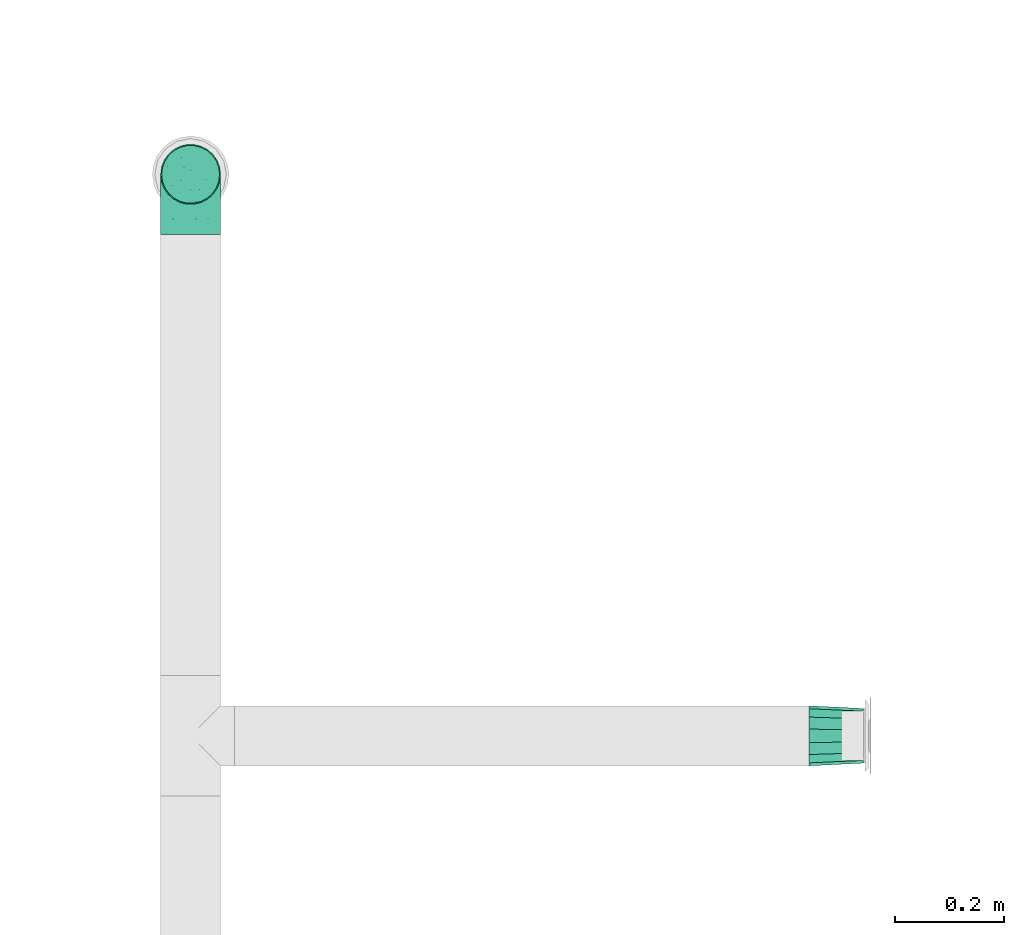
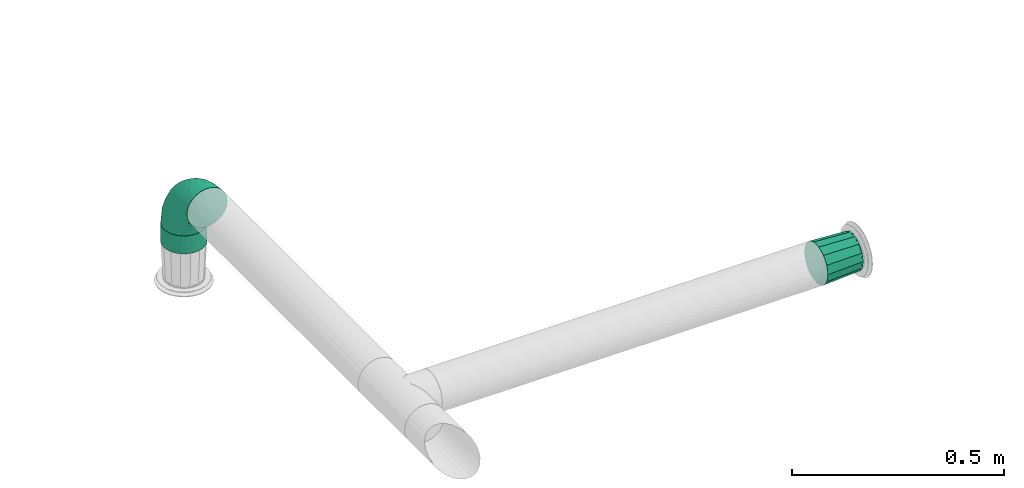
# One storey, part 63 of 115: 2 flow fittings, 1 flow segment.
"""IFC2X3 building model written with IfcOpenShell, lengths in millimetres."""

from ifc_helpers import new_model, entity, si_unit, converted_unit, derived_unit, direction, frame, origin_with_axes, origin_2d_with_axis, place, context, subcontext, project, spatial, hollow_circle, extrude, open_shell, surface_model, source, transform, mapped, material, layer, layer_set, layer_usage, type_object, element, save


model = new_model("IFC2X3")

# Units and contexts
model_context = context("Model", 3, precision=1e-05, world=origin_with_axes(), true_north=direction((0.0, 1.0)))
body_context = subcontext(model_context, "Body", "Model", "MODEL_VIEW")
ifc_project = project(units=[si_unit("AREAUNIT", "SQUARE_METRE"), si_unit("VOLUMEUNIT", "CUBIC_METRE", prefix="DECI"), si_unit("TIMEUNIT", "SECOND"), si_unit("THERMODYNAMICTEMPERATUREUNIT", "DEGREE_CELSIUS"), si_unit("PRESSUREUNIT", "PASCAL"), si_unit("MASSUNIT", "GRAM", prefix="KILO"), si_unit("LENGTHUNIT", "METRE", prefix="MILLI"), si_unit("POWERUNIT", "WATT"), si_unit("ELECTRICCURRENTUNIT", "AMPERE"), si_unit("ELECTRICVOLTAGEUNIT", "VOLT"), derived_unit("VOLUMETRICFLOWRATEUNIT", [(si_unit("VOLUMEUNIT", "CUBIC_METRE", prefix="DECI"), 1), (si_unit("TIMEUNIT", "SECOND"), -1)]), derived_unit("LINEARVELOCITYUNIT", [(si_unit("LENGTHUNIT", "METRE"), 1), (si_unit("TIMEUNIT", "SECOND"), -1)]), derived_unit("MASSDENSITYUNIT", [(si_unit("MASSUNIT", "GRAM", prefix="KILO"), 1), (si_unit("VOLUMEUNIT", "CUBIC_METRE"), -1)]), converted_unit("PLANEANGLEUNIT", "DEGREE", entity("IfcRatioMeasure", 0.01745), si_unit("PLANEANGLEUNIT", "RADIAN"), dimensions=[0, 0, 0, 0, 0, 0, 0])], contexts=[model_context])

# Site, building, storey
site_placement = place(None, origin_with_axes())
site = spatial("IfcSite", under=ifc_project, at=site_placement, CompositionType="ELEMENT")
building_placement = place(site_placement, origin_with_axes())
building = spatial("IfcBuilding", under=site, at=building_placement, Name="mc-building", CompositionType="ELEMENT")
storey_placement = place(building_placement, frame((0.0, 0.0, 2950.0), z_axis=(0.0, 0.0, 1.0), x_axis=(1.0, 0.0, 0.0)))
storey = spatial("IfcBuildingStorey", under=building, at=storey_placement, Name="2. Korrus", CompositionType="ELEMENT", Elevation=2950.0)

# Flow fitting
duct_fitting_type_1 = type_object("IfcDuctFittingType", PredefinedType="TRANSITION")
shared_shape_1 = source(origin_with_axes(), body_context, "Body", "SurfaceModel", [
    surface_model("IfcShellBasedSurfaceModel", [(0.0, 12.94095, 48.29629), (0.0, -35.35534, 35.35534), (0.0, 0.0, 50.0), (0.0, 35.35534, 35.35534), (0.0, 25.0, 43.30127), (0.0, 43.30127, 25.0), (0.0, 48.29629, 12.94095), (0.0, -12.94095, 48.29629), (0.0, -25.0, 43.30127), (0.0, -48.29629, 12.94095), (0.0, -43.30127, 25.0), (0.0, -25.0, -43.30127), (0.0, -48.29629, -12.94095), (0.0, -50.0, 0.0), (0.0, 48.29629, -12.94095), (0.0, 12.94095, -48.29629), (0.0, 43.30127, -25.0), (0.0, 35.35534, -35.35534), (0.0, 25.0, -43.30127), (0.0, -35.35534, -35.35534), (0.0, -43.30127, -25.0), (0.0, -12.94095, -48.29629), (0.0, 0.0, -50.0), (0.0, 50.0, 0.0), (100.0, -55.0, 0.0), (100.0, -12.23865, 53.62104), (100.0, -34.29194, 43.00073), (100.0, 49.55329, -23.86361), (100.0, 12.23865, 53.62104), (100.0, 34.29194, 43.00073), (100.0, 55.0, 0.0), (100.0, 49.55329, 23.86361), (100.0, -49.55329, 23.86361), (100.0, 12.23865, -53.62104), (100.0, -49.55329, -23.86361), (100.0, -34.29194, -43.00073), (100.0, 34.29194, -43.00073), (100.0, -12.23865, -53.62104), (0.0, 11.12605, 48.7464), (0.0, -11.12605, 48.7464), (0.0, 31.17449, 39.09157), (0.0, -45.04844, -21.69419), (0.0, -45.04844, 21.69419), (0.0, -31.17449, 39.09157), (0.0, 45.04844, 21.69419), (0.0, 45.04844, -21.69419), (0.0, 31.17449, -39.09157), (0.0, -31.17449, -39.09157), (0.0, -11.12605, -48.7464), (0.0, 11.12605, -48.7464), (0.0, -47.52422, -10.84709), (100.0, -41.92261, -33.43217), (0.0, -38.11147, -30.39288), (100.0, 41.92261, -33.43217), (0.0, 38.11147, -30.39288), (0.0, -21.15027, -43.91899), (100.0, -23.2653, -48.31088), (100.0, -52.32388, -11.72483), (100.0, 0.0, -53.62104), (0.0, 0.0, -48.7464), (100.0, 23.2653, -48.31088), (0.0, 21.15027, -43.91899), (100.0, 52.32388, -11.72483), (0.0, 47.52422, -10.84709), (0.0, 47.52422, 10.84709), (100.0, 41.92261, 33.43217), (0.0, 38.11147, 30.39288), (100.0, -41.92261, 33.43217), (0.0, -38.11147, 30.39288), (0.0, 21.15027, 43.91899), (100.0, 23.2653, 48.31088), (100.0, 52.32388, 11.72483), (100.0, 0.0, 53.62104), (0.0, 0.0, 48.7464), (100.0, -23.2653, 48.31088), (0.0, -21.15027, 43.91899), (100.0, -52.32388, 11.72483), (0.0, -47.52422, 10.84709), (100.0, 27.5, -47.63139), (100.0, 0.0, -55.0), (100.0, 14.23505, -53.12592), (100.0, 38.89087, -38.89087), (100.0, -27.5, -47.63139), (100.0, 47.63139, -27.5), (100.0, 53.12592, -14.23505), (100.0, -14.23505, -53.12592), (100.0, -47.63139, -27.5), (100.0, -38.89087, -38.89087), (100.0, -53.12592, -14.23505), (100.0, 53.12592, 14.23505), (100.0, 47.63139, 27.5), (100.0, 27.5, 47.63139), (100.0, 38.89087, 38.89087), (100.0, 14.23505, 53.12592), (100.0, 0.0, 55.0), (100.0, -47.63139, 27.5), (100.0, -53.12592, 14.23505), (100.0, -27.5, 47.63139), (100.0, -38.89087, 38.89087), (100.0, -14.23505, 53.12592), (98.0, 0.0, 55.0), (98.0, 14.23505, 53.12592), (98.0, 27.5, 47.63139), (98.0, 38.89087, 38.89087), (98.0, 47.63139, 27.5), (98.0, -47.63139, 27.5), (98.0, 53.12592, -14.23505), (98.0, -27.5, 47.63139), (98.0, -14.23505, 53.12592), (98.0, -38.89087, 38.89087), (98.0, -55.0, 0.0), (98.0, -53.12592, 14.23505), (98.0, 53.12592, 14.23505), (98.0, 47.63139, -27.5), (98.0, -27.5, -47.63139), (98.0, 0.0, -55.0), (98.0, 38.89087, -38.89087), (98.0, 27.5, -47.63139), (98.0, 14.23505, -53.12592), (98.0, -47.63139, -27.5), (98.0, -38.89087, -38.89087), (98.0, -53.12592, -14.23505), (98.0, -14.23505, -53.12592), (98.0, 55.0, 0.0), (2.0, 12.94095, -48.29629), (2.0, 25.0, -43.30127), (2.0, 35.35534, -35.35534), (2.0, 43.30127, -25.0), (2.0, 48.29629, -12.94095), (2.0, 0.0, -50.0), (2.0, 50.0, 0.0), (2.0, -25.0, -43.30127), (2.0, -12.94095, -48.29629), (2.0, -35.35534, -35.35534), (2.0, -48.29629, -12.94095), (2.0, -43.30127, -25.0), (2.0, -48.29629, 12.94095), (2.0, 48.29629, 12.94095), (2.0, 43.30127, 25.0), (2.0, 35.35534, 35.35534), (2.0, -35.35534, 35.35534), (2.0, 12.94095, 48.29629), (2.0, 25.0, 43.30127), (2.0, 0.0, 50.0), (2.0, -43.30127, 25.0), (2.0, -50.0, 0.0), (2.0, -12.94095, 48.29629), (2.0, -25.0, 43.30127)], [open_shell([[[0, 1, 2]], [[3, 0, 4]], [[3, 5, 6]], [[0, 3, 1]], [[6, 1, 3]], [[7, 1, 8]], [[7, 2, 1]], [[1, 9, 10]], [[9, 1, 11]], [[12, 13, 9]], [[11, 1, 6]], [[6, 14, 11]], [[15, 14, 16]], [[17, 18, 15]], [[17, 15, 16]], [[11, 14, 15]], [[12, 19, 20]], [[19, 12, 11]], [[15, 21, 11]], [[12, 9, 11]], [[22, 21, 15]], [[14, 6, 23]], [[24, 25, 26]], [[25, 27, 28]], [[29, 28, 27]], [[27, 30, 31]], [[31, 29, 27]], [[24, 26, 32]], [[33, 24, 34]], [[33, 34, 35]], [[36, 27, 33]], [[33, 27, 24]], [[35, 37, 33]], [[24, 27, 25]], [[38, 23, 39]], [[40, 23, 38]], [[41, 42, 43]], [[41, 13, 42]], [[23, 43, 39]], [[40, 44, 23]], [[41, 23, 45]], [[41, 45, 46]], [[47, 41, 48]], [[49, 48, 41]], [[41, 46, 49]], [[23, 41, 43]], [[34, 50, 41]], [[47, 51, 52]], [[45, 27, 53]], [[36, 54, 53]], [[55, 48, 56]], [[34, 57, 50]], [[57, 13, 50]], [[13, 57, 24]], [[55, 35, 47]], [[35, 51, 47]], [[51, 41, 52]], [[58, 59, 49]], [[60, 61, 46]], [[37, 59, 58]], [[62, 63, 23]], [[35, 55, 56]], [[23, 30, 62]], [[53, 54, 45]], [[48, 37, 56]], [[33, 49, 61]], [[49, 33, 58]], [[54, 36, 46]], [[63, 27, 45]], [[34, 41, 51]], [[33, 61, 60]], [[48, 59, 37]], [[27, 63, 62]], [[46, 36, 60]], [[31, 64, 44]], [[40, 65, 66]], [[42, 32, 67]], [[26, 68, 67]], [[69, 38, 70]], [[31, 71, 64]], [[71, 23, 64]], [[23, 71, 30]], [[69, 29, 40]], [[29, 65, 40]], [[65, 44, 66]], [[72, 73, 39]], [[74, 75, 43]], [[28, 73, 72]], [[76, 77, 13]], [[29, 69, 70]], [[13, 24, 76]], [[67, 68, 42]], [[38, 28, 70]], [[25, 39, 75]], [[39, 25, 72]], [[68, 26, 43]], [[77, 32, 42]], [[31, 44, 65]], [[25, 75, 74]], [[38, 73, 28]], [[32, 77, 76]], [[43, 26, 74]], [[78, 79, 80]], [[81, 82, 78]], [[82, 83, 84]], [[81, 83, 82]], [[30, 82, 84]], [[79, 82, 85]], [[79, 78, 82]], [[82, 86, 87]], [[82, 30, 86]], [[24, 88, 86]], [[86, 30, 89]], [[90, 24, 89]], [[91, 90, 92]], [[91, 93, 94]], [[90, 91, 24]], [[94, 95, 91]], [[24, 95, 96]], [[24, 91, 95]], [[94, 97, 98]], [[98, 95, 94]], [[97, 94, 99]], [[89, 24, 86]], [[100, 101, 102]], [[100, 102, 103]], [[100, 104, 105]], [[104, 100, 103]], [[106, 105, 104]], [[100, 107, 108]], [[100, 109, 107]], [[105, 110, 111]], [[109, 100, 105]], [[105, 106, 110]], [[106, 104, 112]], [[106, 113, 110]], [[113, 114, 110]], [[115, 116, 117]], [[113, 116, 115]], [[117, 118, 115]], [[119, 114, 120]], [[121, 110, 119]], [[114, 115, 122]], [[119, 110, 114]], [[115, 114, 113]], [[123, 106, 112]], [[121, 88, 110]], [[119, 86, 121]], [[82, 120, 114]], [[119, 120, 87]], [[85, 114, 122]], [[121, 86, 88]], [[88, 24, 110]], [[85, 82, 114]], [[87, 120, 82]], [[87, 86, 119]], [[79, 85, 122]], [[122, 115, 79]], [[118, 80, 115]], [[117, 78, 118]], [[83, 116, 113]], [[117, 116, 81]], [[84, 113, 106]], [[117, 81, 78]], [[78, 80, 118]], [[30, 84, 106]], [[83, 113, 84]], [[83, 81, 116]], [[123, 30, 106]], [[115, 80, 79]], [[112, 89, 123]], [[104, 90, 112]], [[91, 103, 102]], [[104, 103, 92]], [[93, 102, 101]], [[112, 90, 89]], [[89, 30, 123]], [[93, 91, 102]], [[92, 103, 91]], [[92, 90, 104]], [[94, 93, 101]], [[101, 100, 94]], [[108, 99, 100]], [[107, 97, 108]], [[95, 109, 105]], [[107, 109, 98]], [[96, 105, 111]], [[107, 98, 97]], [[97, 99, 108]], [[24, 96, 111]], [[95, 105, 96]], [[95, 98, 109]], [[110, 24, 111]], [[100, 99, 94]], [[124, 125, 126]], [[124, 126, 127]], [[124, 128, 129]], [[128, 124, 127]], [[129, 128, 130]], [[129, 131, 132]], [[129, 130, 131]], [[133, 134, 135]], [[134, 133, 131]], [[131, 136, 134]], [[131, 130, 137]], [[137, 138, 139]], [[140, 137, 139]], [[140, 139, 141]], [[141, 139, 142]], [[140, 141, 143]], [[136, 140, 144]], [[145, 134, 136]], [[140, 146, 147]], [[131, 140, 136]], [[143, 146, 140]], [[131, 137, 140]], [[12, 134, 13]], [[20, 135, 12]], [[131, 19, 11]], [[20, 19, 133]], [[132, 11, 21]], [[12, 135, 134]], [[134, 145, 13]], [[132, 131, 11]], [[133, 19, 131]], [[133, 135, 20]], [[129, 132, 21]], [[21, 22, 129]], [[15, 124, 22]], [[18, 125, 15]], [[127, 17, 16]], [[18, 17, 126]], [[128, 16, 14]], [[18, 126, 125]], [[125, 124, 15]], [[130, 128, 14]], [[127, 16, 128]], [[127, 126, 17]], [[23, 130, 14]], [[22, 124, 129]], [[6, 137, 23]], [[5, 138, 6]], [[142, 3, 4]], [[5, 3, 139]], [[141, 4, 0]], [[6, 138, 137]], [[137, 130, 23]], [[141, 142, 4]], [[139, 3, 142]], [[139, 138, 5]], [[143, 141, 0]], [[0, 2, 143]], [[7, 146, 2]], [[8, 147, 7]], [[144, 1, 10]], [[8, 1, 140]], [[136, 10, 9]], [[8, 140, 147]], [[147, 146, 7]], [[145, 136, 9]], [[144, 10, 136]], [[144, 140, 1]], [[13, 145, 9]], [[2, 146, 143]]])]),
])
flow_fitting_1_placement = place(storey_placement, frame((23984.87051, 3666.26111, 2465.0), z_axis=(0.0, 0.0, 1.0), x_axis=(-1.0, 0.0, 0.0)))
element("IfcFlowFitting", 1, at=flow_fitting_1_placement, inside=storey, type_object=duct_fitting_type_1, context=body_context, shape_type="MappedRepresentation", body=[
    mapped(shared_shape_1, transform((0.0, 0.0, 0.0), scale=1.0)),
])

# Flow segment
ifc_material = material(Name="FZ1")
ifc_layer = layer(ifc_material, 0.0)
ifc_layer_set = layer_set([ifc_layer], Name="FZ1")
ifc_layer_usage = layer_usage(ifc_layer_set, "AXIS1", "POSITIVE", 0.0)
duct_segment_type = type_object("IfcDuctSegmentType", PredefinedType="RIGIDSEGMENT")
shared_shape_2 = source(origin_with_axes(), body_context, "Body", "SweptSolid", [
    extrude(hollow_circle(Radius=55.0, WallThickness=2.0, at=origin_2d_with_axis()), frame((0.0, 0.0, 0.0), z_axis=(1.0, 0.0, 0.0), x_axis=(0.0, 1.0, 0.0)), (0.0, 0.0, 1.0), 51.9),
])
flow_segment_placement = place(storey_placement, frame((22753.47863, 4693.85998, 2355.0), z_axis=(0.0, 1.0, 0.0), x_axis=(0.0, 0.0, -1.0)))
element("IfcFlowSegment", 2, at=flow_segment_placement, inside=storey, type_object=duct_segment_type, material=ifc_layer_usage, context=body_context, shape_type="MappedRepresentation", body=[
    mapped(shared_shape_2, transform((0.0, 0.0, 0.0), scale=1.0)),
])

# Flow fitting
duct_fitting_type_2 = type_object("IfcDuctFittingType", Name="BU", PredefinedType="BEND")
shared_shape_3 = source(origin_with_axes(), body_context, "Body", "SurfaceModel", [
    surface_model("IfcShellBasedSurfaceModel", [(-110.0, 0.0, -55.0), (-110.0, -14.23505, -53.12592), (-110.0, 14.23505, -53.12592), (-110.0, 53.12592, 14.23505), (-110.0, 27.5, -47.63139), (-110.0, 38.89087, -38.89087), (-110.0, -55.0, 0.0), (-110.0, -53.12592, 14.23505), (-110.0, -38.89087, -38.89087), (-110.0, -27.5, -47.63139), (-110.0, -53.12592, -14.23505), (-110.0, -47.63139, -27.5), (-110.0, -14.23505, 53.12592), (-110.0, 14.23505, 53.12592), (-110.0, 27.5, 47.63139), (-110.0, -47.63139, 27.5), (-110.0, -38.89087, 38.89087), (-110.0, -27.5, 47.63139), (-110.0, 0.0, 55.0), (-110.0, 55.0, 0.0), (-110.0, 53.12592, -14.23505), (-110.0, 47.63139, -27.5), (-110.0, 47.63139, 27.5), (-110.0, 38.89087, 38.89087), (-14.23505, 110.0, -53.12592), (-55.0, 110.0, 0.0), (0.0, 110.0, -55.0), (-27.5, 110.0, -47.63139), (-38.89087, 110.0, -38.89087), (-47.63139, 110.0, -27.5), (38.89087, 110.0, -38.89087), (53.12592, 110.0, 14.23505), (27.5, 110.0, -47.63139), (14.23505, 110.0, -53.12592), (47.63139, 110.0, -27.5), (53.12592, 110.0, -14.23505), (55.0, 110.0, 0.0), (-53.12592, 110.0, -14.23505), (-53.12592, 110.0, 14.23505), (-47.63139, 110.0, 27.5), (-38.89087, 110.0, 38.89087), (-27.5, 110.0, 47.63139), (0.0, 110.0, 55.0), (-14.23505, 110.0, 53.12592), (38.89087, 110.0, 38.89087), (47.63139, 110.0, 27.5), (27.5, 110.0, 47.63139), (14.23505, 110.0, 53.12592), (-64.21732, 48.68956, 43.63444), (-76.6405, 38.18013, 45.55988), (-60.44912, 32.56953, 51.94617), (-76.00813, 5.38378, 55.0), (-90.15553, 11.94394, 54.09138), (-78.5998, 26.77405, 50.81338), (-70.18771, 18.55163, 54.03432), (-75.55424, 54.2118, 32.41257), (-93.27622, 45.77614, 33.48188), (-96.12334, 22.13664, 50.81337), (-21.00813, 45.34362, 55.0), (-18.36258, 70.48427, 54.04484), (-32.04182, 59.64019, 52.24446), (-63.88653, 74.77858, 17.99134), (-74.66383, 63.08407, 19.92123), (-63.60674, 66.07878, 29.97482), (-99.597, 52.72185, 18.52927), (-93.11138, 56.59448, 10.50359), (-98.21577, 57.34403, 0.0), (-53.42855, 92.60092, 21.04759), (-88.54852, 54.8376, 21.04759), (-11.86161, 90.23965, 54.10313), (-5.38378, 76.00813, 55.0), (-57.34403, 98.21577, 0.0), (-56.64619, 93.12774, 10.22088), (-45.34362, 21.00813, 55.0), (-44.60838, 44.60838, 52.13415), (-92.68484, 35.46673, 43.63443), (-22.25266, 95.40765, 50.81337), (-35.97783, 90.61597, 43.63443), (-43.70931, 69.58671, 44.47149), (-27.23711, 77.39884, 50.81337), (-57.2828, 79.3123, 24.9774), (-58.67786, 84.31125, 16.04456), (-82.93277, 60.36161, 12.91784), (-49.88337, 54.51816, 47.224), (-74.57753, 66.83759, 9.55742), (-45.35812, 94.97281, 33.48188), (-59.18663, 88.95241, 0.0), (-51.517, 78.6292, 33.48188), (-65.14788, 80.03077, 0.0), (-56.45322, 62.06476, 39.63545), (-88.95241, 59.18663, 0.0), (-71.10913, 71.10913, 0.0), (-80.03077, 65.14788, 0.0), (-94.9309, 45.36788, -33.48188), (-93.11358, 56.60141, -10.46614), (-99.64997, 52.79499, -18.30015), (-90.20425, 36.08686, -43.63443), (-79.99933, 46.56772, -37.92748), (-76.00813, 5.38378, -55.0), (-72.75364, 19.68651, -53.60527), (-45.34362, 21.00813, -55.0), (-21.91957, 65.12078, -53.85897), (-5.38378, 76.00813, -55.0), (-21.00813, 45.34362, -55.0), (-35.41876, 92.89265, -43.63443), (-91.10309, 11.02766, -54.21832), (-45.77614, 93.27622, -33.48188), (-90.50474, 23.21022, -50.81337), (-70.92854, 33.31794, -49.51754), (-78.52933, 63.35627, -11.73997), (-24.91508, 84.05606, -50.81337), (-88.78941, 54.74452, -21.04759), (-69.59921, 57.34866, -33.48187), (-73.36422, 62.46673, -22.94182), (-63.49062, 67.59111, -28.46929), (-56.59448, 93.11138, -10.50359), (-54.8376, 88.54852, -21.04759), (-54.10679, 75.85581, -32.31867), (-57.75956, 31.09612, -52.80882), (-52.72185, 99.597, -18.52927), (-12.62913, 89.46304, -53.99097), (-34.46825, 66.46123, -50.04329), (-43.9837, 43.9837, -52.42279), (-65.78527, 72.58348, -17.68796), (-70.34468, 43.65295, -44.21951), (-57.47001, 51.99467, -44.91465), (-60.72547, 82.29174, -12.88567), (-42.34915, 74.24548, -43.63444), (-57.25194, 63.5016, -38.08211), (-80.95344, 53.56991, -29.32027), (-52.32891, 4.55257, -54.0482), (32.52942, 47.13398, -30.48571), (14.88266, 20.92917, -33.7947), (14.95561, 36.05775, -42.26543), (30.24048, 70.09027, -41.7461), (19.3559, 65.35825, -48.00507), (-70.35075, -46.44478, -19.5952), (-47.13398, -32.52942, -30.48571), (-28.49299, -30.5778, -16.4009), (-4.55257, 52.32891, -54.0482), (-22.4954, 22.4954, -53.25347), (-75.47368, -11.22546, -52.60718), (-81.32209, -51.5606, -9.98467), (-80.81763, -41.84862, -32.14655), (-70.09027, -30.24048, -41.7461), (-36.05774, -14.95561, -42.26543), (-9.15831, -10.852, -27.8997), (-65.35825, -19.3559, -48.00507), (11.22546, 75.47368, -52.60718), (3.94376, 43.9333, -50.53315), (-13.39742, 13.39743, -48.13058), (-43.9333, -3.94376, -50.53315), (49.37776, 67.29486, 0.0), (41.8609, 47.82256, -9.92641), (50.20582, 74.51695, -9.9731), (18.93131, 11.7156, -17.56239), (-27.5, -32.89419, 0.0), (-1.23348, -12.25375, -12.18106), (41.84862, 80.81763, -32.14655), (35.70604, 41.31408, -20.38235), (46.44478, 70.35075, -19.5952), (32.89419, 27.5, 0.0), (6.67262, -6.67262, 0.0), (-67.29486, -49.37776, 0.0), (-50.36265, -42.95545, -9.51562), (-5.47251, 5.47251, -39.92906), (-70.35075, -46.44478, 19.5952), (-74.51695, -50.20582, 9.9731), (-41.31407, -35.70604, 20.38235), (-47.13398, -32.52942, 30.48571), (-80.81763, -41.84862, 32.14655), (-4.55257, 52.32891, 54.0482), (11.22546, 75.47368, 52.60718), (-43.9333, -3.94376, 50.53315), (-65.35825, -19.3559, 48.00507), (-36.05774, -14.95561, 42.26543), (-70.09027, -30.24048, 41.7461), (-11.7156, -18.93131, 17.56239), (30.5778, 28.49299, 16.4009), (12.25375, 1.23348, 12.18106), (51.5606, 81.32209, 9.98467), (42.95545, 50.36265, 9.51562), (-75.47368, -11.22546, 52.60718), (-52.32891, 4.55257, 54.0482), (3.94376, 43.9333, 50.53315), (-22.4954, 22.4954, 53.25347), (-13.39742, 13.39743, 48.13058), (10.852, 9.15831, 27.8997), (-20.92916, -14.88266, 33.79469), (-47.82256, -41.8609, 9.92641), (32.52942, 47.13398, 30.48571), (46.44478, 70.35075, 19.5952), (41.84862, 80.81763, 32.14655), (30.24048, 70.09027, 41.7461), (19.3559, 65.35825, 48.00507), (14.95561, 36.05775, 42.26543), (-5.47251, 5.47251, 39.92906)], [open_shell([[[0, 1, 2]], [[2, 3, 4]], [[4, 3, 5]], [[2, 6, 7]], [[8, 6, 9]], [[1, 9, 6]], [[10, 6, 11]], [[8, 11, 6]], [[6, 2, 1]], [[12, 13, 14]], [[15, 2, 7]], [[16, 17, 2]], [[2, 17, 12]], [[12, 18, 13]], [[19, 20, 3]], [[5, 3, 21]], [[20, 21, 3]], [[22, 3, 2]], [[23, 22, 2]], [[12, 14, 2]], [[2, 14, 23]], [[15, 16, 2]], [[24, 25, 26]], [[27, 25, 24]], [[25, 28, 29]], [[28, 25, 27]], [[30, 26, 31]], [[26, 30, 32]], [[32, 33, 26]], [[34, 31, 35]], [[31, 34, 30]], [[35, 31, 36]], [[29, 37, 25]], [[38, 39, 26]], [[39, 40, 26]], [[41, 42, 40]], [[42, 26, 40]], [[42, 41, 43]], [[26, 44, 45]], [[31, 26, 45]], [[26, 46, 44]], [[47, 46, 26]], [[42, 47, 26]], [[25, 38, 26]], [[48, 49, 50]], [[18, 51, 52]], [[53, 54, 50]], [[55, 56, 49]], [[56, 22, 23]], [[13, 57, 14]], [[58, 59, 60]], [[61, 62, 63]], [[3, 64, 65]], [[53, 52, 54]], [[3, 65, 66]], [[67, 39, 38]], [[56, 68, 64]], [[65, 64, 68]], [[69, 59, 70]], [[38, 71, 72]], [[73, 58, 74]], [[75, 49, 56]], [[76, 69, 43]], [[53, 57, 52]], [[77, 78, 79]], [[41, 76, 43]], [[43, 69, 42]], [[55, 68, 56]], [[23, 14, 75]], [[76, 77, 79]], [[80, 67, 81]], [[62, 82, 68]], [[60, 78, 83]], [[62, 84, 82]], [[85, 77, 40]], [[81, 67, 72]], [[86, 72, 71]], [[87, 85, 67]], [[61, 81, 88]], [[77, 41, 40]], [[78, 77, 87]], [[23, 75, 56]], [[83, 89, 48]], [[85, 40, 39]], [[62, 68, 55]], [[89, 87, 63]], [[83, 48, 50]], [[57, 75, 14]], [[49, 75, 53]], [[67, 85, 39]], [[87, 77, 85]], [[63, 62, 55]], [[89, 55, 48]], [[80, 63, 87]], [[66, 65, 90]], [[66, 19, 3]], [[84, 91, 92]], [[92, 90, 82]], [[65, 82, 90]], [[61, 84, 62]], [[92, 82, 84]], [[68, 82, 65]], [[3, 22, 64]], [[56, 64, 22]], [[38, 25, 71]], [[81, 72, 86]], [[38, 72, 67]], [[91, 61, 88]], [[80, 81, 61]], [[63, 80, 61]], [[67, 80, 87]], [[77, 76, 41]], [[79, 59, 69]], [[79, 69, 76]], [[42, 69, 70]], [[60, 59, 79]], [[58, 70, 59]], [[78, 60, 79]], [[58, 60, 74]], [[52, 57, 13]], [[75, 57, 53]], [[18, 52, 13]], [[52, 51, 54]], [[51, 73, 54]], [[50, 73, 74]], [[73, 50, 54]], [[50, 74, 83]], [[60, 83, 74]], [[89, 83, 78]], [[87, 89, 78]], [[55, 89, 63]], [[50, 49, 53]], [[55, 49, 48]], [[81, 86, 88]], [[91, 84, 61]], [[5, 21, 93]], [[90, 94, 66]], [[20, 94, 95]], [[96, 93, 97]], [[98, 99, 100]], [[96, 4, 5]], [[101, 102, 103]], [[28, 27, 104]], [[2, 105, 0]], [[104, 106, 28]], [[99, 105, 107]], [[108, 107, 96]], [[90, 109, 94]], [[107, 2, 4]], [[20, 66, 94]], [[27, 24, 110]], [[109, 111, 94]], [[112, 113, 114]], [[37, 115, 71]], [[116, 106, 117]], [[99, 118, 100]], [[116, 115, 119]], [[37, 119, 115]], [[24, 120, 110]], [[121, 110, 101]], [[119, 106, 116]], [[101, 110, 120]], [[122, 103, 100]], [[117, 123, 116]], [[124, 125, 108]], [[115, 116, 126]], [[106, 29, 28]], [[26, 102, 120]], [[127, 104, 110]], [[97, 124, 96]], [[125, 122, 118]], [[128, 127, 125]], [[96, 5, 93]], [[115, 126, 86]], [[117, 106, 127]], [[111, 113, 129]], [[95, 93, 21]], [[97, 129, 112]], [[110, 104, 27]], [[106, 104, 127]], [[96, 107, 4]], [[99, 107, 108]], [[99, 108, 118]], [[105, 99, 98]], [[112, 114, 128]], [[121, 125, 127]], [[20, 19, 66]], [[109, 90, 92]], [[94, 111, 95]], [[91, 123, 109]], [[129, 113, 112]], [[93, 95, 111]], [[21, 20, 95]], [[71, 115, 86]], [[71, 25, 37]], [[123, 91, 88]], [[126, 116, 123]], [[123, 88, 126]], [[86, 126, 88]], [[37, 29, 119]], [[106, 119, 29]], [[129, 93, 111]], [[124, 112, 125]], [[0, 105, 98]], [[107, 105, 2]], [[125, 118, 108]], [[100, 118, 122]], [[93, 129, 97]], [[113, 111, 109]], [[109, 123, 113]], [[114, 123, 117]], [[123, 114, 113]], [[128, 114, 117]], [[127, 128, 117]], [[112, 128, 125]], [[103, 122, 101]], [[110, 121, 127]], [[101, 122, 121]], [[125, 121, 122]], [[26, 120, 24]], [[101, 120, 102]], [[96, 124, 108]], [[92, 91, 109]], [[112, 124, 97]], [[100, 130, 98]], [[131, 132, 133]], [[32, 134, 135]], [[136, 137, 138]], [[139, 140, 103]], [[98, 141, 0]], [[142, 10, 136]], [[143, 144, 137]], [[6, 10, 142]], [[137, 145, 146]], [[144, 147, 145]], [[143, 136, 11]], [[11, 136, 10]], [[8, 143, 11]], [[148, 149, 139]], [[8, 9, 144]], [[9, 1, 147]], [[130, 141, 98]], [[103, 140, 100]], [[148, 135, 149]], [[150, 151, 140]], [[152, 153, 154]], [[130, 140, 151]], [[148, 26, 33]], [[147, 1, 141]], [[155, 146, 132]], [[156, 138, 157]], [[134, 30, 158]], [[150, 140, 149]], [[158, 30, 34]], [[30, 134, 32]], [[153, 159, 160]], [[131, 160, 159]], [[144, 145, 137]], [[36, 152, 154]], [[146, 138, 137]], [[155, 161, 162]], [[158, 160, 131]], [[133, 149, 135]], [[156, 163, 164]], [[163, 142, 164]], [[139, 103, 102]], [[153, 152, 161]], [[34, 35, 160]], [[162, 157, 155]], [[132, 165, 133]], [[157, 146, 155]], [[140, 130, 100]], [[141, 130, 151]], [[141, 151, 147]], [[141, 1, 0]], [[102, 26, 148]], [[140, 139, 149]], [[102, 148, 139]], [[135, 33, 32]], [[151, 150, 145]], [[9, 147, 144]], [[151, 145, 147]], [[145, 165, 146]], [[135, 148, 33]], [[133, 135, 134]], [[131, 133, 134]], [[133, 165, 150]], [[133, 150, 149]], [[145, 150, 165]], [[132, 131, 159]], [[146, 165, 132]], [[160, 158, 34]], [[134, 158, 131]], [[144, 143, 8]], [[136, 143, 137]], [[155, 153, 161]], [[154, 153, 160]], [[153, 155, 159]], [[132, 159, 155]], [[160, 35, 154]], [[36, 154, 35]], [[164, 136, 138]], [[6, 142, 163]], [[136, 164, 142]], [[156, 164, 138]], [[156, 157, 162]], [[146, 157, 138]], [[15, 7, 166]], [[6, 163, 167]], [[168, 169, 166]], [[166, 169, 170]], [[171, 172, 70]], [[173, 174, 175]], [[17, 176, 174]], [[177, 156, 162]], [[176, 16, 170]], [[170, 16, 15]], [[161, 178, 179]], [[152, 180, 181]], [[182, 173, 183]], [[18, 12, 182]], [[184, 185, 186]], [[183, 185, 73]], [[183, 73, 51]], [[177, 187, 188]], [[189, 168, 166]], [[187, 178, 190]], [[16, 176, 17]], [[161, 152, 181]], [[45, 191, 31]], [[45, 44, 192]], [[192, 191, 45]], [[180, 36, 31]], [[193, 194, 195]], [[46, 47, 194]], [[193, 195, 190]], [[193, 44, 46]], [[172, 42, 70]], [[185, 58, 73]], [[189, 163, 156]], [[163, 189, 167]], [[70, 58, 171]], [[184, 171, 185]], [[169, 188, 175]], [[180, 31, 191]], [[192, 193, 190]], [[191, 190, 178]], [[182, 174, 173]], [[194, 47, 172]], [[190, 195, 187]], [[186, 185, 173]], [[162, 179, 177]], [[188, 196, 175]], [[179, 187, 177]], [[185, 171, 58]], [[172, 171, 184]], [[172, 184, 194]], [[172, 47, 42]], [[51, 18, 182]], [[185, 183, 173]], [[51, 182, 183]], [[174, 12, 17]], [[184, 186, 195]], [[46, 194, 193]], [[184, 195, 194]], [[195, 196, 187]], [[174, 182, 12]], [[175, 174, 176]], [[169, 175, 176]], [[175, 196, 186]], [[175, 186, 173]], [[195, 186, 196]], [[188, 169, 168]], [[187, 196, 188]], [[166, 170, 15]], [[176, 170, 169]], [[193, 192, 44]], [[191, 192, 190]], [[177, 189, 156]], [[167, 189, 166]], [[189, 177, 168]], [[188, 168, 177]], [[166, 7, 167]], [[6, 167, 7]], [[181, 191, 178]], [[36, 180, 152]], [[191, 181, 180]], [[161, 181, 178]], [[161, 179, 162]], [[187, 179, 178]]])]),
])
flow_fitting_2_placement = place(storey_placement, frame((22753.47863, 4693.85998, 2465.0), z_axis=(-1.0, 0.0, 0.0), x_axis=(0.0, 1.0, 0.0)))
element("IfcFlowFitting", 3, at=flow_fitting_2_placement, inside=storey, type_object=duct_fitting_type_2, Name="BU", context=body_context, shape_type="MappedRepresentation", body=[
    mapped(shared_shape_3, transform((0.0, 0.0, 0.0), scale=1.0)),
])

save(model, "model.ifc")
